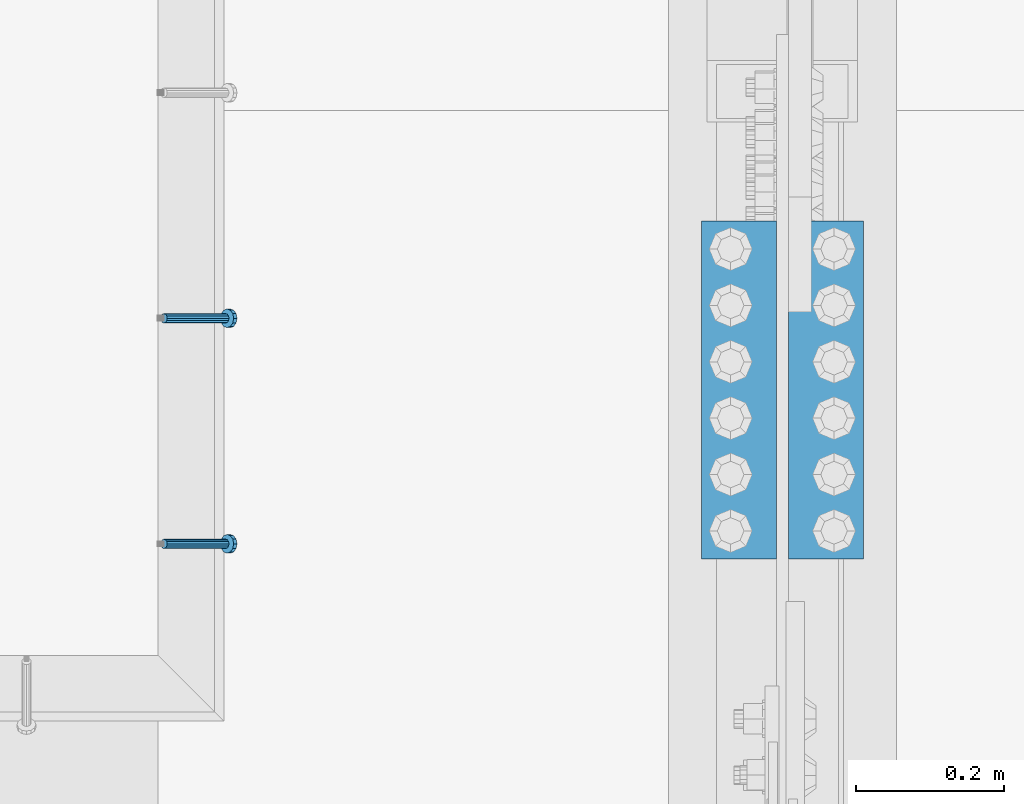
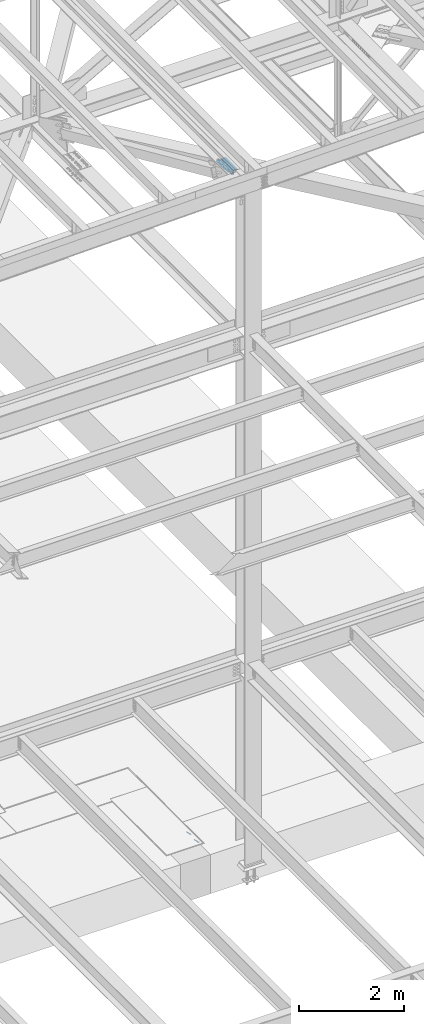
# One storey, part 2168 of 3843: 2 beams, 2 members, 2 elements without a shape of their own.
"""IFC2X3 building model written with IfcOpenShell, lengths in millimetres."""

from ifc_helpers import new_model, si_unit, frame, origin_with_axes, place, context, subcontext, project, spatial, faceted_brep, material, type_object, element, aggregate, save


model = new_model("IFC2X3")

# Units and contexts
model_context = context("Model", 3, precision=1e-05, world=origin_with_axes())
body_context = subcontext(model_context, "Body", "Model", "MODEL_VIEW")
ifc_project = project(units=[si_unit("LENGTHUNIT", "METRE", prefix="MILLI"), si_unit("AREAUNIT", "SQUARE_METRE"), si_unit("VOLUMEUNIT", "CUBIC_METRE"), si_unit("MASSUNIT", "GRAM", prefix="KILO"), si_unit("TIMEUNIT", "SECOND"), si_unit("PLANEANGLEUNIT", "RADIAN"), si_unit("SOLIDANGLEUNIT", "STERADIAN"), si_unit("THERMODYNAMICTEMPERATUREUNIT", "DEGREE_CELSIUS"), si_unit("LUMINOUSINTENSITYUNIT", "LUMEN")], contexts=[model_context])

# Site, building, storey
site_placement = place(None, origin_with_axes())
site = spatial("IfcSite", under=ifc_project, at=site_placement, CompositionType="ELEMENT")
building_placement = place(site_placement, origin_with_axes())
building = spatial("IfcBuilding", under=site, at=building_placement, Name="Undefined", CompositionType="ELEMENT")
storey_placement = place(building_placement, origin_with_axes())
storey = spatial("IfcBuildingStorey", under=building, at=storey_placement, Name="Undefined", CompositionType="ELEMENT", Elevation=0.0)

# Assembly, members
assembly_1_placement = place(storey_placement, origin_with_axes())
assembly_1 = element("IfcElementAssembly", 1, at=assembly_1_placement, inside=storey, Name="EMBED_ANGLE", AssemblyPlace="NOTDEFINED", PredefinedType="RIGID_FRAME")
ifc_material_1 = material(Name="STEEL/A108")
member_type = type_object("IfcMemberType", PredefinedType="NOTDEFINED")
member_1_placement = place(assembly_1_placement, frame((69420.5494374184, 26544.5875018083, 30446.6625), z_axis=(0.0, 1.0, 0.0), x_axis=(0.707106781186548, 0.0, -0.707106781186548)))
member_1 = element("IfcMember", 2, at=member_1_placement, type_object=member_type, material=ifc_material_1, Name="HEADED STUD ANCHOR", context=body_context, shape_type="Brep", body=[
    faceted_brep([(7.27595761418343e-12, -3.18000006675175, 5.5), (0.0, -5.49999999998363, 3.1800000667572), (118.110000000976, -5.49999999999091, 3.1800000667572), (118.110000000983, -3.18000006675175, 5.5), (0.0, -6.3499999046162, 0.0), (118.110000000968, -6.34999990461256, 0.0), (0.0, -5.49999999998363, -3.1800000667572), (118.110000000976, -5.49999999999091, -3.1800000667572), (7.27595761418343e-12, -3.18000006675175, -5.5), (118.110000000983, -3.18000006675175, -5.5), (7.27595761418343e-12, -1.81898940354586e-12, -6.34999990463257), (118.110000000968, -1.81898940354586e-12, -6.34999990463257), (0.0, 3.18000006675175, -5.5), (118.110000000968, 3.18000006674811, -5.5), (7.27595761418343e-12, 5.49999999998363, -3.1800000667572), (118.110000000983, 5.49999999998363, -3.1800000667572), (7.27595761418343e-12, 6.3499999046162, 0.0), (118.110000000976, 6.34999990461256, 0.0), (7.27595761418343e-12, 5.49999999998363, 3.1800000667572), (118.110000000983, 5.49999999998363, 3.1800000667572), (0.0, 3.18000006675175, 5.5), (118.110000000968, 3.18000006674811, 5.5), (7.27595761418343e-12, -1.81898940354586e-12, 6.34999990463257), (118.110000000968, -1.81898940354586e-12, 6.34999990463257), (120.650000000991, -10.9899997710909, 6.34999990463257), (120.650000000998, -6.34000015257152, 10.9899997711182), (120.650000000991, -12.6999998092379, 0.0), (120.650000000991, -10.9899997710909, -6.34999990463257), (120.650000000998, -6.34000015257152, -10.9899997711182), (120.650000000991, -1.81898940354586e-12, -12.6899995803833), (120.650000000991, 6.34000015257152, -10.9899997711182), (120.650000000998, 10.9899997710909, -6.34999990463257), (120.650000000991, 12.6999998092342, 0.0), (120.650000000998, 10.9899997710909, 6.34999990463257), (120.650000000991, 6.34000015257152, 10.9899997711182), (120.650000000991, -1.81898940354586e-12, 12.6899995803833), (127.000000001048, -10.9899997710945, 6.34999990463257), (127.000000001048, -6.34000015257152, 10.9899997711182), (127.000000001048, -12.6999998092342, 0.0), (127.000000001048, -10.9899997710945, -6.34999990463257), (127.000000001048, -6.34000015257152, -10.9899997711182), (127.000000001048, 1.81898940354586e-12, -12.6899995803833), (127.000000001048, 6.34000015256788, -10.9899997711182), (127.000000001048, 10.9899997710909, -6.34999990463257), (127.000000001048, 12.6999998092379, 0.0), (127.000000001048, 10.9899997710909, 6.34999990463257), (127.000000001048, 6.34000015256788, 10.9899997711182), (127.000000001048, 1.81898940354586e-12, 12.6899995803833)], [[[0, 1, 2, 3]], [[1, 4, 5, 2]], [[4, 6, 7, 5]], [[6, 8, 9, 7]], [[8, 10, 11, 9]], [[10, 12, 13, 11]], [[12, 14, 15, 13]], [[14, 16, 17, 15]], [[16, 18, 19, 17]], [[18, 20, 21, 19]], [[20, 22, 23, 21]], [[22, 0, 3, 23]], [[22, 20, 18, 16, 14, 12, 10, 8, 6, 4, 1, 0]], [[3, 2, 24, 25]], [[2, 5, 26, 24]], [[5, 7, 27, 26]], [[7, 9, 28, 27]], [[9, 11, 29, 28]], [[11, 13, 30, 29]], [[13, 15, 31, 30]], [[15, 17, 32, 31]], [[17, 19, 33, 32]], [[19, 21, 34, 33]], [[21, 23, 35, 34]], [[23, 3, 25, 35]], [[25, 24, 36, 37]], [[24, 26, 38, 36]], [[26, 27, 39, 38]], [[27, 28, 40, 39]], [[28, 29, 41, 40]], [[29, 30, 42, 41]], [[30, 31, 43, 42]], [[31, 32, 44, 43]], [[32, 33, 45, 44]], [[33, 34, 46, 45]], [[34, 35, 47, 46]], [[35, 25, 37, 47]], [[38, 39, 40, 41, 42, 43, 44, 45, 46, 47, 37, 36]]]),
])
member_2_placement = place(assembly_1_placement, frame((69420.5494374184, 26239.7875018083, 30446.6625), z_axis=(0.0, 1.0, 0.0), x_axis=(0.707106781186548, 0.0, -0.707106781186548)))
member_2 = element("IfcMember", 3, at=member_2_placement, type_object=member_type, material=ifc_material_1, Name="HEADED STUD ANCHOR", context=body_context, shape_type="Brep", body=[
    faceted_brep([(7.27595761418343e-12, -3.18000006675175, 5.5), (0.0, -5.49999999998363, 3.1800000667572), (118.110000000976, -5.49999999999091, 3.1800000667572), (118.110000000983, -3.18000006675175, 5.5), (0.0, -6.3499999046162, 0.0), (118.110000000968, -6.34999990461256, 0.0), (0.0, -5.49999999998363, -3.1800000667572), (118.110000000976, -5.49999999999091, -3.1800000667572), (7.27595761418343e-12, -3.18000006675175, -5.5), (118.110000000983, -3.18000006675175, -5.5), (7.27595761418343e-12, -1.81898940354586e-12, -6.34999990463257), (118.110000000968, -1.81898940354586e-12, -6.34999990463257), (0.0, 3.18000006675175, -5.5), (118.110000000968, 3.18000006674811, -5.5), (7.27595761418343e-12, 5.49999999998363, -3.1800000667572), (118.110000000983, 5.49999999998363, -3.1800000667572), (7.27595761418343e-12, 6.3499999046162, 0.0), (118.110000000976, 6.34999990461256, 0.0), (7.27595761418343e-12, 5.49999999998363, 3.1800000667572), (118.110000000983, 5.49999999998363, 3.1800000667572), (0.0, 3.18000006675175, 5.5), (118.110000000968, 3.18000006674811, 5.5), (7.27595761418343e-12, -1.81898940354586e-12, 6.34999990463257), (118.110000000968, -1.81898940354586e-12, 6.34999990463257), (120.650000000991, -10.9899997710909, 6.34999990463257), (120.650000000998, -6.34000015257152, 10.9899997711182), (120.650000000991, -12.6999998092379, 0.0), (120.650000000991, -10.9899997710909, -6.34999990463257), (120.650000000998, -6.34000015257152, -10.9899997711182), (120.650000000991, -1.81898940354586e-12, -12.6899995803833), (120.650000000991, 6.34000015257152, -10.9899997711182), (120.650000000998, 10.9899997710909, -6.34999990463257), (120.650000000991, 12.6999998092342, 0.0), (120.650000000998, 10.9899997710909, 6.34999990463257), (120.650000000991, 6.34000015257152, 10.9899997711182), (120.650000000991, -1.81898940354586e-12, 12.6899995803833), (127.000000001048, -10.9899997710945, 6.34999990463257), (127.000000001048, -6.34000015257152, 10.9899997711182), (127.000000001048, -12.6999998092342, 0.0), (127.000000001048, -10.9899997710945, -6.34999990463257), (127.000000001048, -6.34000015257152, -10.9899997711182), (127.000000001048, 1.81898940354586e-12, -12.6899995803833), (127.000000001048, 6.34000015256788, -10.9899997711182), (127.000000001048, 10.9899997710909, -6.34999990463257), (127.000000001048, 12.6999998092379, 0.0), (127.000000001048, 10.9899997710909, 6.34999990463257), (127.000000001048, 6.34000015256788, 10.9899997711182), (127.000000001048, 1.81898940354586e-12, 12.6899995803833)], [[[0, 1, 2, 3]], [[1, 4, 5, 2]], [[4, 6, 7, 5]], [[6, 8, 9, 7]], [[8, 10, 11, 9]], [[10, 12, 13, 11]], [[12, 14, 15, 13]], [[14, 16, 17, 15]], [[16, 18, 19, 17]], [[18, 20, 21, 19]], [[20, 22, 23, 21]], [[22, 0, 3, 23]], [[22, 20, 18, 16, 14, 12, 10, 8, 6, 4, 1, 0]], [[3, 2, 24, 25]], [[2, 5, 26, 24]], [[5, 7, 27, 26]], [[7, 9, 28, 27]], [[9, 11, 29, 28]], [[11, 13, 30, 29]], [[13, 15, 31, 30]], [[15, 17, 32, 31]], [[17, 19, 33, 32]], [[19, 21, 34, 33]], [[21, 23, 35, 34]], [[23, 3, 25, 35]], [[25, 24, 36, 37]], [[24, 26, 38, 36]], [[26, 27, 39, 38]], [[27, 28, 40, 39]], [[28, 29, 41, 40]], [[29, 30, 42, 41]], [[30, 31, 43, 42]], [[31, 32, 44, 43]], [[32, 33, 45, 44]], [[33, 34, 46, 45]], [[34, 35, 47, 46]], [[35, 25, 37, 47]], [[38, 39, 40, 41, 42, 43, 44, 45, 46, 47, 37, 36]]]),
])
aggregate(assembly_1, [member_1, member_2])

# Assembly, beams
assembly_2_placement = place(storey_placement, origin_with_axes())
assembly_2 = element("IfcElementAssembly", 4, at=assembly_2_placement, inside=storey, Name="PLATE", AssemblyPlace="NOTDEFINED", PredefinedType="RIGID_FRAME")
ifc_material_2 = material(Name="STEEL/A572-50")
beam_type = type_object("IfcBeamType", Name="L4X4X1/2", PredefinedType="NOTDEFINED")
beam_1_placement = place(assembly_2_placement, frame((70315.1375, 26676.35, 45745.5121849565), z_axis=(0.0, 0.0, -1.0), x_axis=(0.0, -1.0, 0.0)))
beam_1 = element("IfcBeam", 5, at=beam_1_placement, type_object=beam_type, material=ifc_material_2, Name="ANGLE", ObjectType="L4X4X1/2", context=body_context, shape_type="Brep", body=[
    faceted_brep([(0.0, 50.8000000000029, -50.8000000000029), (0.0, 50.8000000000029, 50.8000000000029), (457.199999999997, 50.8000000000029, 50.8000000000029), (457.199999999997, 50.8000000000029, -50.8000000000029), (0.0, 38.0999999999985, 50.8000000000029), (457.199999999997, 38.0999999999985, 50.8000000000029), (0.0, 38.0999999999985, -38.0999999999985), (457.199999999997, 38.0999999999985, -38.0999999999985), (0.0, -50.8000000000029, -38.1000000000058), (457.199999999997, -50.8000000000029, -38.0999999999985), (0.0, -50.8000000000029, -50.8000000000029), (457.199999999997, -50.8000000000029, -50.8000000000029)], [[[0, 1, 2, 3]], [[1, 4, 5, 2]], [[4, 6, 7, 5]], [[6, 8, 9, 7]], [[8, 10, 11, 9]], [[10, 0, 3, 11]], [[5, 7, 9, 11, 3, 2]], [[10, 8, 6, 4, 1, 0]]]),
])
beam_2_placement = place(assembly_2_placement, frame((70197.6625, 26219.15, 45745.5121849565), z_axis=(0.0, 0.0, -1.0), x_axis=(0.0, 1.0, 0.0)))
beam_2 = element("IfcBeam", 6, at=beam_2_placement, type_object=beam_type, material=ifc_material_2, Name="ANGLE", ObjectType="L4X4X1/2", context=body_context, shape_type="Brep", body=[
    faceted_brep([(0.0, 50.8000000000029, -50.8000000000029), (0.0, 50.8000000000029, 50.8000000000029), (457.199999999997, 50.8000000000029, 50.8000000000029), (457.199999999997, 50.8000000000029, -50.8000000000029), (0.0, 38.0999999999985, 50.8000000000029), (457.199999999997, 38.0999999999985, 50.8000000000029), (0.0, 38.0999999999985, -38.0999999999985), (457.199999999997, 38.0999999999985, -38.0999999999985), (0.0, -50.8000000000029, -38.1000000000058), (457.199999999997, -50.8000000000029, -38.0999999999985), (0.0, -50.8000000000029, -50.8000000000029), (457.199999999997, -50.8000000000029, -50.8000000000029)], [[[0, 1, 2, 3]], [[1, 4, 5, 2]], [[4, 6, 7, 5]], [[6, 8, 9, 7]], [[8, 10, 11, 9]], [[10, 0, 3, 11]], [[5, 7, 9, 11, 3, 2]], [[10, 8, 6, 4, 1, 0]]]),
])
aggregate(assembly_2, [beam_1, beam_2])

save(model, "model.ifc")
